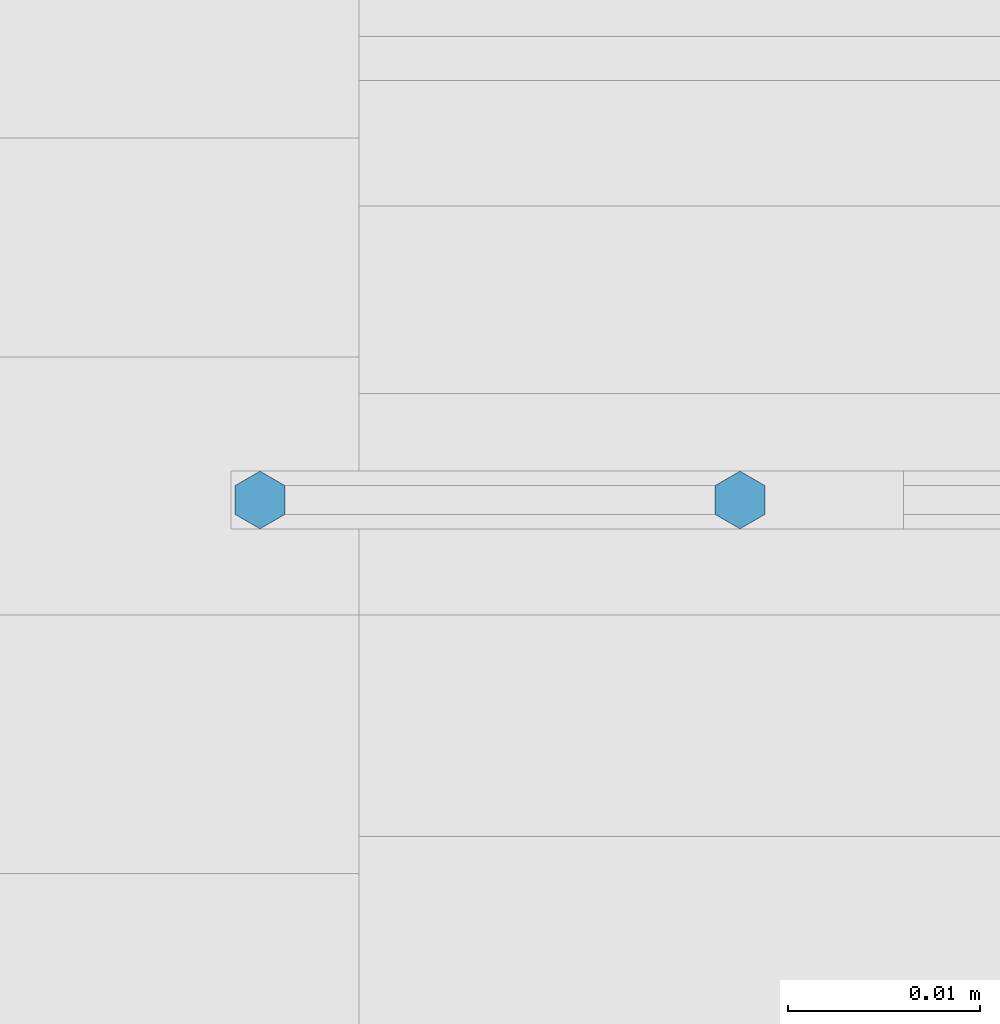
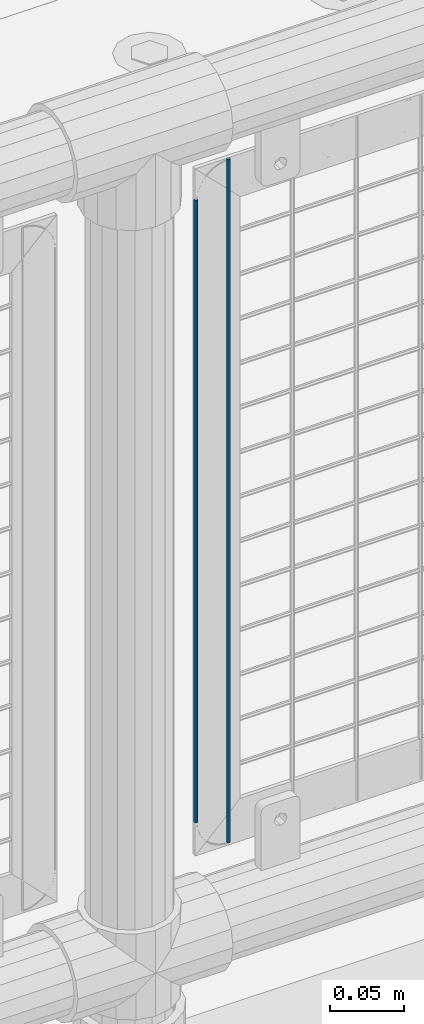
# One storey, part 84 of 247: 2 columns.
"""IFC2X3 building model written with IfcOpenShell, lengths in millimetres."""

from ifc_helpers import new_model, si_unit, frame, origin_with_axes, place, context, subcontext, project, spatial, faceted_brep, material, type_object, element, save


model = new_model("IFC2X3")

# Units and contexts
model_context = context("Model", 3, precision=1e-05, world=origin_with_axes())
body_context = subcontext(model_context, "Body", "Model", "MODEL_VIEW")
ifc_project = project(units=[si_unit("LENGTHUNIT", "METRE", prefix="MILLI"), si_unit("AREAUNIT", "SQUARE_METRE"), si_unit("VOLUMEUNIT", "CUBIC_METRE"), si_unit("MASSUNIT", "GRAM", prefix="KILO"), si_unit("TIMEUNIT", "SECOND"), si_unit("PLANEANGLEUNIT", "RADIAN"), si_unit("SOLIDANGLEUNIT", "STERADIAN"), si_unit("THERMODYNAMICTEMPERATUREUNIT", "DEGREE_CELSIUS"), si_unit("LUMINOUSINTENSITYUNIT", "LUMEN")], contexts=[model_context])

# Site, building, storey
site_placement = place(None, origin_with_axes())
site = spatial("IfcSite", under=ifc_project, at=site_placement, CompositionType="ELEMENT")
building_placement = place(site_placement, origin_with_axes())
building = spatial("IfcBuilding", under=site, at=building_placement, Name="Standard", CompositionType="ELEMENT")
storey_placement = place(building_placement, origin_with_axes())
storey = spatial("IfcBuildingStorey", under=building, at=storey_placement, Name="Undefined", CompositionType="ELEMENT", Elevation=0.0)

# Columns
ifc_material = material(Name="Misc_Undefined")
column_type = type_object("IfcColumnType", Name="D3", PredefinedType="NOTDEFINED")
column_1_placement = place(storey_placement, frame((7076.0, 7670.5, 378.020000000002), z_axis=(-1.0, 0.0, 0.0), x_axis=(0.0, 0.0, 1.0)))
element("IfcColumn", 1, at=column_1_placement, inside=storey, type_object=column_type, material=ifc_material, ObjectType="D3", context=body_context, shape_type="Brep", body=[
    faceted_brep([(1.81898940354586e-12, -1.5, -5.6843418860808e-14), (0.0, -0.75, -1.29903810567703), (510.0, -0.75, -1.29903810567703), (510.0, -1.5, 0.0), (0.0, 0.75, -1.29903810567703), (510.0, 0.75, -1.29903810567703), (1.81898940354586e-12, 1.5, -5.6843418860808e-14), (510.0, 1.5, 0.0), (0.0, 0.75, 1.29903810567703), (510.0, 0.75, 1.29903810567703), (0.0, -0.75, 1.29903810567703), (510.0, -0.75, 1.29903810567703)], [[[0, 1, 2, 3]], [[1, 4, 5, 2]], [[4, 6, 7, 5]], [[6, 8, 9, 7]], [[8, 10, 11, 9]], [[10, 0, 3, 11]], [[5, 7, 9, 11, 3, 2]], [[10, 8, 6, 4, 1, 0]]]),
])
column_2_placement = place(storey_placement, frame((7101.0, 7670.5, 353.020000000002), z_axis=(-1.0, 0.0, 0.0), x_axis=(0.0, 0.0, 1.0)))
element("IfcColumn", 2, at=column_2_placement, inside=storey, type_object=column_type, material=ifc_material, ObjectType="D3", context=body_context, shape_type="Brep", body=[
    faceted_brep([(1.81898940354586e-12, -1.5, -5.6843418860808e-14), (0.0, -0.75, -1.29903810567703), (560.0, -0.75, -1.29903810567703), (560.0, -1.5, 0.0), (0.0, 0.75, -1.29903810567703), (560.0, 0.75, -1.29903810567703), (1.81898940354586e-12, 1.5, -5.6843418860808e-14), (560.0, 1.5, 0.0), (0.0, 0.75, 1.29903810567703), (560.0, 0.75, 1.29903810567703), (0.0, -0.75, 1.29903810567703), (560.0, -0.75, 1.29903810567703)], [[[0, 1, 2, 3]], [[1, 4, 5, 2]], [[4, 6, 7, 5]], [[6, 8, 9, 7]], [[8, 10, 11, 9]], [[10, 0, 3, 11]], [[5, 7, 9, 11, 3, 2]], [[10, 8, 6, 4, 1, 0]]]),
])

save(model, "model.ifc")
